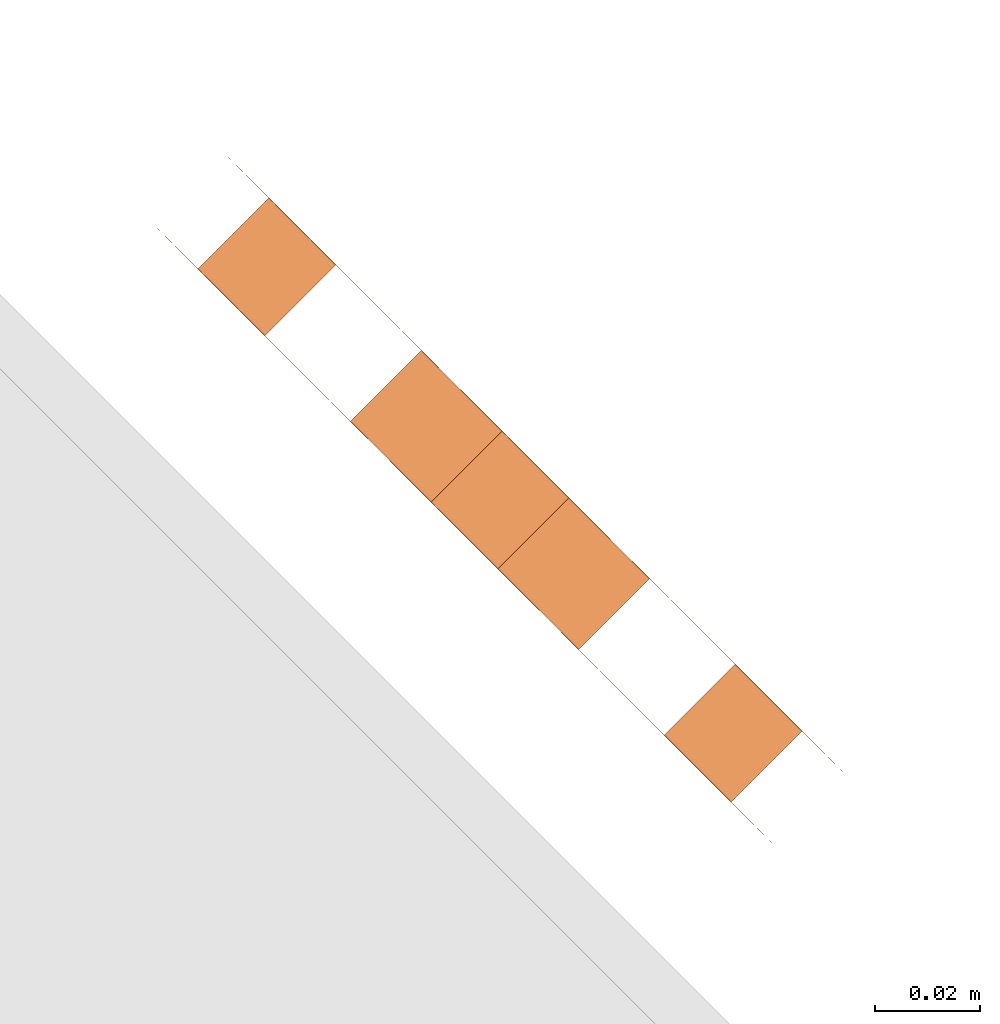
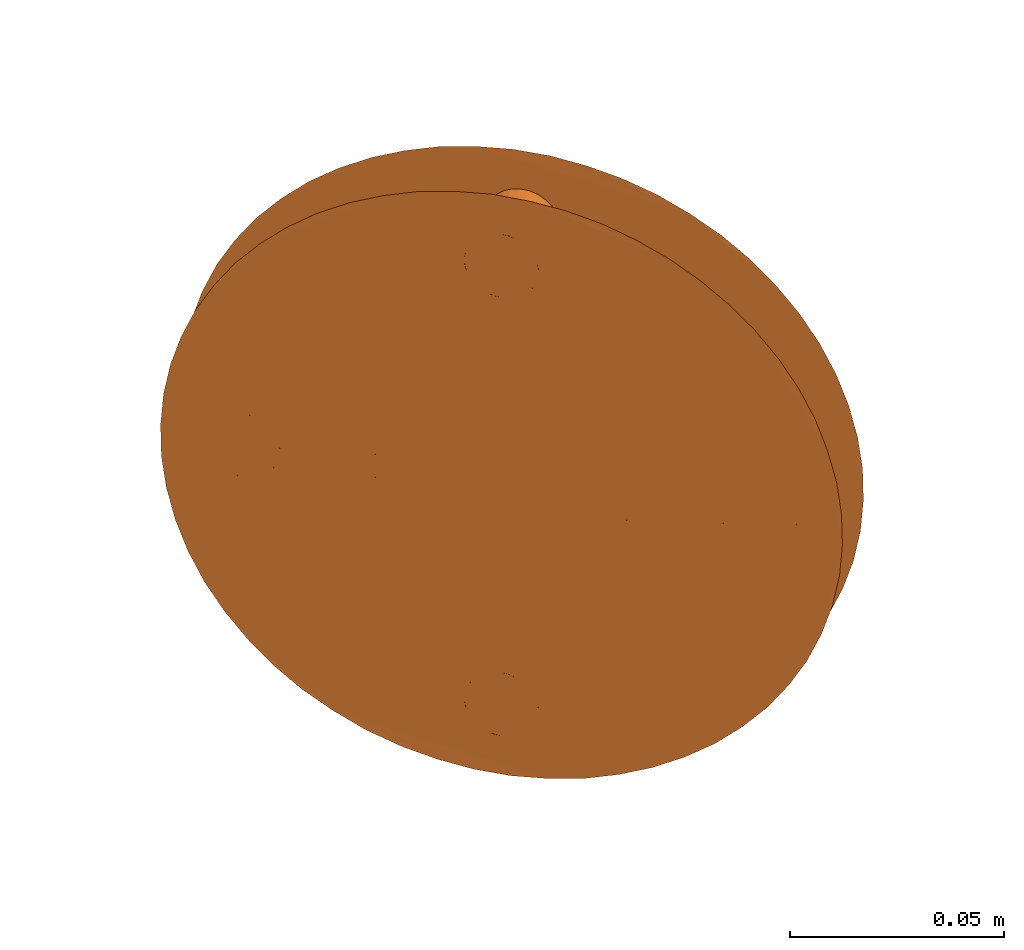
# One storey, part 95 of 126: 1 proxy.
"""IFC2X3 building model written with IfcOpenShell, lengths in millimetres."""

from ifc_helpers import new_model, si_unit, origin, origin_with_axes, place, context, project, spatial, faceted_brep, material, element, save


model = new_model("IFC2X3")

# Units and contexts
context_of_model_1 = context(None, 3, precision=0.1, world=origin())
context_of_model_2 = context(None, 3, precision=0.1, world=origin())
ifc_project = project(units=[si_unit("LENGTHUNIT", "METRE", prefix="MILLI"), si_unit("AREAUNIT", "SQUARE_METRE", prefix="CENTI"), si_unit("VOLUMEUNIT", "CUBIC_METRE", prefix="CENTI"), si_unit("MASSUNIT", "GRAM", prefix="KILO")], contexts=[context_of_model_1, context_of_model_2])

# Site, building, storey
site_placement = place(None, origin_with_axes())
site = spatial("IfcSite", under=ifc_project, at=site_placement, CompositionType="ELEMENT")
building_placement = place(site_placement, origin_with_axes())
building = spatial("IfcBuilding", under=site, at=building_placement, CompositionType="ELEMENT")
storey_placement = place(building_placement, origin_with_axes())
storey = spatial("IfcBuildingStorey", under=building, at=storey_placement, CompositionType="ELEMENT")

# Proxy
ifc_material = material(Name="STAHL")
proxy_placement = place(storey_placement, origin_with_axes())
element("IfcBuildingElementProxy", 1, at=proxy_placement, inside=storey, material=ifc_material, Name="profile", context=context_of_model_2, shape_type="Brep", body=[
    faceted_brep([(13723.0, 13606.4, 1593.8), (13722.5, 13606.9, 1584.9), (13721.3, 13608.1, 1576.1), (13719.4, 13609.9, 1567.6), (13716.9, 13612.4, 1559.3), (13713.8, 13615.5, 1551.6), (13710.2, 13619.2, 1544.3), (13705.9, 13623.4, 1537.7), (13701.2, 13628.1, 1531.7), (13696.1, 13633.3, 1526.5), (13690.6, 13638.8, 1522.1), (13684.8, 13644.6, 1518.6), (13678.8, 13650.6, 1515.9), (13672.6, 13656.8, 1514.3), (13666.3, 13663.1, 1513.5), (13659.9, 13669.4, 1513.8), (13653.7, 13675.7, 1515.0), (13647.6, 13681.8, 1517.1), (13641.6, 13687.7, 1520.2), (13636.0, 13693.4, 1524.2), (13630.6, 13698.7, 1529.0), (13625.7, 13703.6, 1534.6), (13621.3, 13708.1, 1540.9), (13617.3, 13712.1, 1547.9), (13613.9, 13715.5, 1555.4), (13611.1, 13718.3, 1563.4), (13622.4, 13733.9, 1571.8), (13624.5, 13731.7, 1563.4), (13627.3, 13728.9, 1555.4), (13630.7, 13725.5, 1547.9), (13634.7, 13721.5, 1540.9), (13639.2, 13717.1, 1534.6), (13644.1, 13712.2, 1529.0), (13649.4, 13706.8, 1524.2), (13655.1, 13701.2, 1520.2), (13661.0, 13695.2, 1517.1), (13667.1, 13689.1, 1515.0), (13673.4, 13682.9, 1513.8), (13679.7, 13676.5, 1513.5), (13686.0, 13670.2, 1514.3), (13692.2, 13664.0, 1515.9), (13698.2, 13658.0, 1518.6), (13704.0, 13652.2, 1522.1), (13709.5, 13646.7, 1526.5), (13714.7, 13641.6, 1531.7), (13719.4, 13636.9, 1537.7), (13723.6, 13632.6, 1544.3), (13727.3, 13629.0, 1551.6), (13730.4, 13625.9, 1559.3), (13732.9, 13623.4, 1567.6), (13734.7, 13621.5, 1576.1), (13735.9, 13620.3, 1584.9), (13736.4, 13619.8, 1593.8), (13736.3, 13620.0, 1602.7), (13735.4, 13620.8, 1611.5), (13733.9, 13622.4, 1620.2), (13731.7, 13624.5, 1628.6), (13728.9, 13627.3, 1636.6), (13725.5, 13630.7, 1644.1), (13721.5, 13634.7, 1651.1), (13717.1, 13639.2, 1657.4), (13712.2, 13644.1, 1663.0), (13706.8, 13649.4, 1667.8), (13701.2, 13655.1, 1671.8), (13695.2, 13661.0, 1674.9), (13689.1, 13667.1, 1677.0), (13682.9, 13673.4, 1678.2), (13676.5, 13679.7, 1678.5), (13670.2, 13686.0, 1677.7), (13664.0, 13692.2, 1676.1), (13658.0, 13698.2, 1673.4), (13652.2, 13704.0, 1669.9), (13646.7, 13709.5, 1665.5), (13641.6, 13714.7, 1660.3), (13636.9, 13719.4, 1654.3), (13632.6, 13723.6, 1647.7), (13629.0, 13727.3, 1640.4), (13625.9, 13730.4, 1632.7), (13623.4, 13732.9, 1624.4), (13621.5, 13734.7, 1615.9), (13620.3, 13735.9, 1607.1), (13619.8, 13736.4, 1598.2), (13620.0, 13736.3, 1589.3), (13620.8, 13735.4, 1580.5), (13608.9, 13720.4, 1571.8), (13607.4, 13722.0, 1580.5), (13606.5, 13722.8, 1589.3), (13606.4, 13723.0, 1598.2), (13606.9, 13722.5, 1607.1), (13608.1, 13721.3, 1615.9), (13609.9, 13719.4, 1624.4), (13612.4, 13716.9, 1632.7), (13615.5, 13713.8, 1640.4), (13619.2, 13710.2, 1647.7), (13623.4, 13705.9, 1654.3), (13628.1, 13701.2, 1660.3), (13633.3, 13696.1, 1665.5), (13638.8, 13690.6, 1669.9), (13644.6, 13684.8, 1673.4), (13650.6, 13678.8, 1676.1), (13656.8, 13672.6, 1677.7), (13663.1, 13666.3, 1678.5), (13669.4, 13659.9, 1678.2), (13675.7, 13653.7, 1677.0), (13681.8, 13647.6, 1674.9), (13687.7, 13641.6, 1671.8), (13693.4, 13636.0, 1667.8), (13698.7, 13630.6, 1663.0), (13703.6, 13625.7, 1657.4), (13708.1, 13621.3, 1651.1), (13712.1, 13617.3, 1644.1), (13715.5, 13613.9, 1636.6), (13718.3, 13611.1, 1628.6), (13720.4, 13608.9, 1620.2), (13722.0, 13607.4, 1611.5), (13722.8, 13606.5, 1602.7), (13690.6, 13665.6, 1570.8), (13677.2, 13652.2, 1570.8), (13680.1, 13649.3, 1574.3), (13693.5, 13662.7, 1574.3), (13687.3, 13668.9, 1568.1), (13673.9, 13655.5, 1568.1), (13683.7, 13672.5, 1566.3), (13670.3, 13659.1, 1566.3), (13680.0, 13676.2, 1565.4), (13666.6, 13662.8, 1565.4), (13676.2, 13680.0, 1565.4), (13662.8, 13666.6, 1565.4), (13672.5, 13683.7, 1566.3), (13659.1, 13670.3, 1566.3), (13668.9, 13687.3, 1568.1), (13655.5, 13673.9, 1568.1), (13665.6, 13690.6, 1570.8), (13652.2, 13677.2, 1570.8), (13662.7, 13693.5, 1574.3), (13649.3, 13680.1, 1574.3), (13660.3, 13695.9, 1578.4), (13646.9, 13682.5, 1578.4), (13658.4, 13697.8, 1583.0), (13645.0, 13684.4, 1583.0), (13657.1, 13699.1, 1588.0), (13643.7, 13685.7, 1588.0), (13656.5, 13699.8, 1593.3), (13643.0, 13686.3, 1593.3), (13656.5, 13699.8, 1598.7), (13643.0, 13686.3, 1598.7), (13657.1, 13699.1, 1604.0), (13643.7, 13685.7, 1604.0), (13658.4, 13697.8, 1609.0), (13645.0, 13684.4, 1609.0), (13660.3, 13695.9, 1613.6), (13646.9, 13682.5, 1613.6), (13662.7, 13693.5, 1617.7), (13649.3, 13680.1, 1617.7), (13725.6, 13630.6, 1588.3), (13712.2, 13617.2, 1588.3), (13713.4, 13616.0, 1589.6), (13726.8, 13629.4, 1589.6), (13724.2, 13632.0, 1587.4), (13710.8, 13618.6, 1587.4), (13722.7, 13633.5, 1587.0), (13709.3, 13620.1, 1587.0), (13721.2, 13635.1, 1587.1), (13707.7, 13621.6, 1587.1), (13719.7, 13636.5, 1587.8), (13706.3, 13623.1, 1587.8), (13718.4, 13637.8, 1588.9), (13705.0, 13624.4, 1588.9), (13717.3, 13638.9, 1590.4), (13703.9, 13625.5, 1590.4), (13716.5, 13639.7, 1592.3), (13703.1, 13626.3, 1592.3), (13716.1, 13640.2, 1594.4), (13702.6, 13626.7, 1594.4), (13716.0, 13640.3, 1596.5), (13702.5, 13626.8, 1596.5), (13716.2, 13640.0, 1598.7), (13702.8, 13626.6, 1598.7), (13716.9, 13639.4, 1600.7), (13703.4, 13625.9, 1600.7), (13717.8, 13638.4, 1602.4), (13704.4, 13625.0, 1602.4), (13637.2, 13719.0, 1588.3), (13623.8, 13705.6, 1588.3), (13625.0, 13704.4, 1589.6), (13638.4, 13717.8, 1589.6), (13635.8, 13720.4, 1587.4), (13622.4, 13707.0, 1587.4), (13634.3, 13721.9, 1587.0), (13620.9, 13708.5, 1587.0), (13632.8, 13723.5, 1587.1), (13619.3, 13710.0, 1587.1), (13631.3, 13724.9, 1587.8), (13617.9, 13711.5, 1587.8), (13630.0, 13726.2, 1588.9), (13616.6, 13712.8, 1588.9), (13628.9, 13727.3, 1590.4), (13615.5, 13713.9, 1590.4), (13628.1, 13728.1, 1592.3), (13614.7, 13714.7, 1592.3), (13627.7, 13728.6, 1594.4), (13614.2, 13715.1, 1594.4), (13627.6, 13728.7, 1596.5), (13614.1, 13715.2, 1596.5), (13627.8, 13728.4, 1598.7), (13614.4, 13715.0, 1598.7), (13628.5, 13727.8, 1600.7), (13615.0, 13714.3, 1600.7), (13629.4, 13726.8, 1602.4), (13616.0, 13713.4, 1602.4), (13681.4, 13674.8, 1525.8), (13668.0, 13661.4, 1525.8), (13669.2, 13660.2, 1527.1), (13682.6, 13673.6, 1527.1), (13680.0, 13676.2, 1524.9), (13666.6, 13662.8, 1524.9), (13678.5, 13677.7, 1524.5), (13665.1, 13664.3, 1524.5), (13677.0, 13679.3, 1524.6), (13663.5, 13665.8, 1524.6), (13675.5, 13680.7, 1525.3), (13662.1, 13667.3, 1525.3), (13674.2, 13682.0, 1526.4), (13660.8, 13668.6, 1526.4), (13673.1, 13683.1, 1527.9), (13659.7, 13669.7, 1527.9), (13672.3, 13683.9, 1529.8), (13658.9, 13670.5, 1529.8), (13671.9, 13684.4, 1531.9), (13658.4, 13670.9, 1531.9), (13671.8, 13684.5, 1534.0), (13658.3, 13671.0, 1534.0), (13672.0, 13684.2, 1536.2), (13658.6, 13670.8, 1536.2), (13672.7, 13683.6, 1538.2), (13659.2, 13670.1, 1538.2), (13673.6, 13682.6, 1539.9), (13660.2, 13669.2, 1539.9), (13681.4, 13674.8, 1650.8), (13668.0, 13661.4, 1650.8), (13669.2, 13660.2, 1652.1), (13682.6, 13673.6, 1652.1), (13680.0, 13676.2, 1649.9), (13666.6, 13662.8, 1649.9), (13678.5, 13677.7, 1649.5), (13665.1, 13664.3, 1649.5), (13677.0, 13679.3, 1649.6), (13663.5, 13665.8, 1649.6), (13675.5, 13680.7, 1650.3), (13662.1, 13667.3, 1650.3), (13674.2, 13682.0, 1651.4), (13660.8, 13668.6, 1651.4), (13673.1, 13683.1, 1652.9), (13659.7, 13669.7, 1652.9), (13672.3, 13683.9, 1654.8), (13658.9, 13670.5, 1654.8), (13671.9, 13684.4, 1656.9), (13658.4, 13670.9, 1656.9), (13671.8, 13684.5, 1659.0), (13658.3, 13671.0, 1659.0), (13672.0, 13684.2, 1661.2), (13658.6, 13670.8, 1661.2), (13672.7, 13683.6, 1663.2), (13659.2, 13670.1, 1663.2), (13673.6, 13682.6, 1664.9), (13660.2, 13669.2, 1664.9), (13674.8, 13681.4, 1666.2), (13661.4, 13668.0, 1666.2), (13676.2, 13680.0, 1667.1), (13662.8, 13666.6, 1667.1), (13677.7, 13678.5, 1667.5), (13664.3, 13665.1, 1667.5), (13679.3, 13677.0, 1667.4), (13665.8, 13663.5, 1667.4), (13680.7, 13675.5, 1666.7), (13667.3, 13662.1, 1666.7), (13682.0, 13674.2, 1665.6), (13668.6, 13660.8, 1665.6), (13683.1, 13673.1, 1664.1), (13669.7, 13659.7, 1664.1), (13683.9, 13672.3, 1662.2), (13670.5, 13658.9, 1662.2), (13684.4, 13671.9, 1660.1), (13670.9, 13658.4, 1660.1), (13684.5, 13671.8, 1658.0), (13671.0, 13658.3, 1658.0), (13684.2, 13672.0, 1655.8), (13670.8, 13658.6, 1655.8), (13683.6, 13672.7, 1653.8), (13670.1, 13659.2, 1653.8), (13674.8, 13681.4, 1541.2), (13661.4, 13668.0, 1541.2), (13676.2, 13680.0, 1542.1), (13662.8, 13666.6, 1542.1), (13677.7, 13678.5, 1542.5), (13664.3, 13665.1, 1542.5), (13679.3, 13677.0, 1542.4), (13665.8, 13663.5, 1542.4), (13680.7, 13675.5, 1541.7), (13667.3, 13662.1, 1541.7), (13682.0, 13674.2, 1540.6), (13668.6, 13660.8, 1540.6), (13683.1, 13673.1, 1539.1), (13669.7, 13659.7, 1539.1), (13683.9, 13672.3, 1537.2), (13670.5, 13658.9, 1537.2), (13684.4, 13671.9, 1535.1), (13670.9, 13658.4, 1535.1), (13684.5, 13671.8, 1533.0), (13671.0, 13658.3, 1533.0), (13684.2, 13672.0, 1530.8), (13670.8, 13658.6, 1530.8), (13683.6, 13672.7, 1528.8), (13670.1, 13659.2, 1528.8), (13630.6, 13725.6, 1603.7), (13617.2, 13712.2, 1603.7), (13632.0, 13724.2, 1604.6), (13618.6, 13710.8, 1604.6), (13633.5, 13722.7, 1605.0), (13620.1, 13709.3, 1605.0), (13635.1, 13721.2, 1604.9), (13621.6, 13707.7, 1604.9), (13636.5, 13719.7, 1604.2), (13623.1, 13706.3, 1604.2), (13637.8, 13718.4, 1603.1), (13624.4, 13705.0, 1603.1), (13638.9, 13717.3, 1601.6), (13625.5, 13703.9, 1601.6), (13639.7, 13716.5, 1599.7), (13626.3, 13703.1, 1599.7), (13640.2, 13716.1, 1597.6), (13626.7, 13702.6, 1597.6), (13640.3, 13716.0, 1595.5), (13626.8, 13702.5, 1595.5), (13640.0, 13716.2, 1593.3), (13626.6, 13702.8, 1593.3), (13639.4, 13716.9, 1591.3), (13625.9, 13703.4, 1591.3), (13719.0, 13637.2, 1603.7), (13705.6, 13623.8, 1603.7), (13720.4, 13635.8, 1604.6), (13707.0, 13622.4, 1604.6), (13721.9, 13634.3, 1605.0), (13708.5, 13620.9, 1605.0), (13723.5, 13632.8, 1604.9), (13710.0, 13619.3, 1604.9), (13724.9, 13631.3, 1604.2), (13711.5, 13617.9, 1604.2), (13726.2, 13630.0, 1603.1), (13712.8, 13616.6, 1603.1), (13727.3, 13628.9, 1601.6), (13713.9, 13615.5, 1601.6), (13728.1, 13628.1, 1599.7), (13714.7, 13614.7, 1599.7), (13728.6, 13627.7, 1597.6), (13715.1, 13614.2, 1597.6), (13728.7, 13627.6, 1595.5), (13715.2, 13614.1, 1595.5), (13728.4, 13627.8, 1593.3), (13715.0, 13614.4, 1593.3), (13727.8, 13628.5, 1591.3), (13714.3, 13615.0, 1591.3), (13695.9, 13660.3, 1578.4), (13697.8, 13658.4, 1583.0), (13699.1, 13657.1, 1588.0), (13699.8, 13656.5, 1593.3), (13699.8, 13656.5, 1598.7), (13699.1, 13657.1, 1604.0), (13697.8, 13658.4, 1609.0), (13695.9, 13660.3, 1613.6), (13693.5, 13662.7, 1617.7), (13690.6, 13665.6, 1621.2), (13687.3, 13668.9, 1623.9), (13683.7, 13672.5, 1625.7), (13680.0, 13676.2, 1626.6), (13676.2, 13680.0, 1626.6), (13672.5, 13683.7, 1625.7), (13668.9, 13687.3, 1623.9), (13665.6, 13690.6, 1621.2), (13652.2, 13677.2, 1621.2), (13655.5, 13673.9, 1623.9), (13659.1, 13670.3, 1625.7), (13662.8, 13666.6, 1626.6), (13666.6, 13662.8, 1626.6), (13670.3, 13659.1, 1625.7), (13673.9, 13655.5, 1623.9), (13677.2, 13652.2, 1621.2), (13680.1, 13649.3, 1617.7), (13682.5, 13646.9, 1613.6), (13684.4, 13645.0, 1609.0), (13685.7, 13643.7, 1604.0), (13686.3, 13643.0, 1598.7), (13686.3, 13643.0, 1593.3), (13685.7, 13643.7, 1588.0), (13684.4, 13645.0, 1583.0), (13682.5, 13646.9, 1578.4)], [[[0, 1, 2, 3, 4, 5, 6, 7, 8, 9, 10, 11, 12, 13, 14, 15, 16, 17, 18, 19, 20, 21, 22, 23, 24, 25, 26, 27, 28, 29, 30, 31, 32, 33, 34, 35, 36, 37, 38, 39, 40, 41, 42, 43, 44, 45, 46, 47, 48, 49, 50, 51, 52, 53, 54, 55, 56, 57, 58, 59, 60, 61, 62, 63, 64, 65, 66, 67, 68, 69, 70, 71, 72, 73, 74, 75, 76, 77, 78, 79, 80, 81, 82, 83, 26, 25, 84, 85, 86, 87, 88, 89, 90, 91, 92, 93, 94, 95, 96, 97, 98, 99, 100, 101, 102, 103, 104, 105, 106, 107, 108, 109, 110, 111, 112, 113, 114, 115]], [[116, 117, 118, 119]], [[120, 121, 117, 116]], [[122, 123, 121, 120]], [[124, 125, 123, 122]], [[126, 127, 125, 124]], [[128, 129, 127, 126]], [[130, 131, 129, 128]], [[132, 133, 131, 130]], [[134, 135, 133, 132]], [[136, 137, 135, 134]], [[138, 139, 137, 136]], [[140, 141, 139, 138]], [[142, 143, 141, 140]], [[144, 145, 143, 142]], [[146, 147, 145, 144]], [[148, 149, 147, 146]], [[150, 151, 149, 148]], [[152, 153, 151, 150]], [[154, 155, 156, 157]], [[158, 159, 155, 154]], [[160, 161, 159, 158]], [[162, 163, 161, 160]], [[164, 165, 163, 162]], [[166, 167, 165, 164]], [[168, 169, 167, 166]], [[170, 171, 169, 168]], [[172, 173, 171, 170]], [[174, 175, 173, 172]], [[176, 177, 175, 174]], [[178, 179, 177, 176]], [[180, 181, 179, 178]], [[182, 183, 184, 185]], [[186, 187, 183, 182]], [[188, 189, 187, 186]], [[190, 191, 189, 188]], [[192, 193, 191, 190]], [[194, 195, 193, 192]], [[196, 197, 195, 194]], [[198, 199, 197, 196]], [[200, 201, 199, 198]], [[202, 203, 201, 200]], [[204, 205, 203, 202]], [[206, 207, 205, 204]], [[208, 209, 207, 206]], [[210, 211, 212, 213]], [[214, 215, 211, 210]], [[216, 217, 215, 214]], [[218, 219, 217, 216]], [[220, 221, 219, 218]], [[222, 223, 221, 220]], [[224, 225, 223, 222]], [[226, 227, 225, 224]], [[228, 229, 227, 226]], [[230, 231, 229, 228]], [[232, 233, 231, 230]], [[234, 235, 233, 232]], [[236, 237, 235, 234]], [[238, 239, 240, 241]], [[242, 243, 239, 238]], [[244, 245, 243, 242]], [[246, 247, 245, 244]], [[248, 249, 247, 246]], [[250, 251, 249, 248]], [[252, 253, 251, 250]], [[254, 255, 253, 252]], [[256, 257, 255, 254]], [[258, 259, 257, 256]], [[260, 261, 259, 258]], [[262, 263, 261, 260]], [[264, 265, 263, 262]], [[266, 267, 265, 264]], [[266, 268, 269, 267]], [[268, 270, 271, 269]], [[270, 272, 273, 271]], [[272, 274, 275, 273]], [[274, 276, 277, 275]], [[276, 278, 279, 277]], [[278, 280, 281, 279]], [[280, 282, 283, 281]], [[282, 284, 285, 283]], [[284, 286, 287, 285]], [[286, 288, 289, 287]], [[288, 241, 240, 289]], [[290, 291, 237, 236]], [[290, 292, 293, 291]], [[292, 294, 295, 293]], [[294, 296, 297, 295]], [[296, 298, 299, 297]], [[298, 300, 301, 299]], [[300, 302, 303, 301]], [[302, 304, 305, 303]], [[304, 306, 307, 305]], [[306, 308, 309, 307]], [[308, 310, 311, 309]], [[310, 312, 313, 311]], [[312, 213, 212, 313]], [[314, 315, 209, 208]], [[316, 317, 315, 314]], [[318, 319, 317, 316]], [[320, 321, 319, 318]], [[322, 323, 321, 320]], [[324, 325, 323, 322]], [[326, 327, 325, 324]], [[326, 328, 329, 327]], [[328, 330, 331, 329]], [[330, 332, 333, 331]], [[332, 334, 335, 333]], [[334, 336, 337, 335]], [[185, 184, 337, 336]], [[338, 339, 181, 180]], [[340, 341, 339, 338]], [[342, 343, 341, 340]], [[344, 345, 343, 342]], [[346, 347, 345, 344]], [[348, 349, 347, 346]], [[350, 351, 349, 348]], [[350, 352, 353, 351]], [[352, 354, 355, 353]], [[354, 356, 357, 355]], [[356, 358, 359, 357]], [[358, 360, 361, 359]], [[157, 156, 361, 360]], [[52, 51, 50, 49, 48, 47, 46, 45, 44, 43, 42, 41, 40, 39, 38, 37, 36, 35, 34, 33, 32, 234, 232, 230, 228, 226, 224, 222, 220, 218, 216, 214, 210, 213, 312, 310, 308, 306, 304, 302, 300, 298, 296, 294, 292, 290, 236, 234, 32, 31, 30, 29, 28, 27, 26, 83, 82, 81, 80, 79, 78, 77, 76, 322, 320, 318, 316, 314, 208, 206, 204, 202, 200, 198, 196, 194, 192, 190, 188, 186, 182, 185, 336, 334, 332, 330, 328, 326, 324, 322, 76, 75, 74, 73, 72, 71, 70, 69, 68, 67, 66, 65, 64, 63, 62, 61, 288, 286, 284, 282, 280, 278, 276, 274, 272, 270, 268, 266, 264, 262, 260, 258, 256, 254, 252, 250, 248, 246, 244, 242, 238, 241, 288, 61, 60, 59, 58, 338, 180, 178, 176, 174, 172, 170, 168, 166, 362, 363, 364, 365, 366, 367, 368, 369, 370, 371, 372, 373, 374, 375, 376, 377, 378, 152, 150, 148, 146, 144, 142, 140, 138, 136, 134, 132, 130, 128, 126, 124, 122, 120, 116, 119, 362, 166, 164, 162, 160, 158, 154, 157, 360, 358, 356, 354, 352, 350, 348, 346, 344, 342, 340, 338, 58, 57, 56, 55, 54, 53]], [[0, 115, 114, 113, 112, 111, 110, 109, 108, 107, 106, 105, 104, 103, 102, 101, 100, 99, 98, 97, 96, 95, 94, 93, 92, 91, 90, 89, 88, 87, 86, 85, 84, 193, 195, 197, 199, 201, 203, 205, 207, 209, 315, 317, 319, 321, 323, 325, 327, 329, 331, 333, 335, 337, 184, 183, 137, 139, 141, 143, 145, 147, 149, 151, 153, 379, 380, 381, 382, 383, 384, 385, 386, 289, 240, 239, 243, 245, 247, 249, 251, 253, 255, 257, 259, 261, 263, 265, 267, 269, 271, 273, 275, 277, 279, 281, 283, 285, 287, 289, 386, 387, 388, 389, 390, 391, 392, 393, 394, 395, 165, 167, 169, 171, 173, 175, 177, 179, 181, 339, 341, 343, 345, 347, 349, 351, 353, 355, 357, 359, 361, 156, 155, 159, 161, 163, 165, 395, 118, 117, 121, 123, 125, 127, 129, 131, 133, 235, 237, 291, 293, 295, 297, 299, 301, 303, 305, 307, 309, 311, 313, 212, 211, 215, 217, 219, 221, 223, 225, 227, 229, 231, 233, 235, 133, 135, 137, 183, 187, 189, 191, 193, 84, 25, 24, 23, 22, 21, 20, 19, 18, 17, 16, 15, 14, 13, 12, 11, 10, 9, 8, 7, 6, 5, 4, 3, 2, 1]], [[378, 379, 153, 152]], [[378, 377, 380, 379]], [[377, 376, 381, 380]], [[376, 375, 382, 381]], [[375, 374, 383, 382]], [[374, 373, 384, 383]], [[373, 372, 385, 384]], [[372, 371, 386, 385]], [[371, 370, 387, 386]], [[370, 369, 388, 387]], [[369, 368, 389, 388]], [[368, 367, 390, 389]], [[367, 366, 391, 390]], [[366, 365, 392, 391]], [[365, 364, 393, 392]], [[364, 363, 394, 393]], [[363, 362, 395, 394]], [[362, 119, 118, 395]]]),
])

save(model, "model.ifc")
